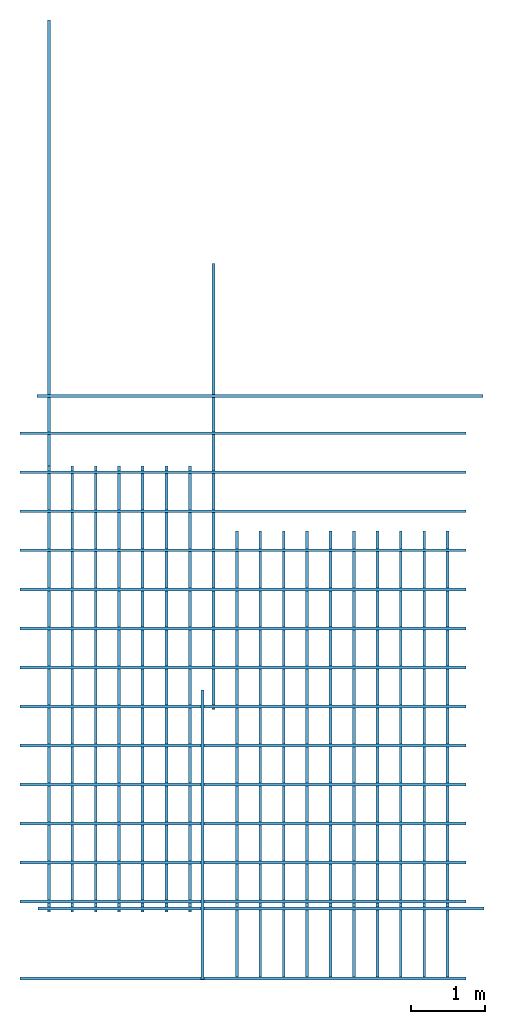
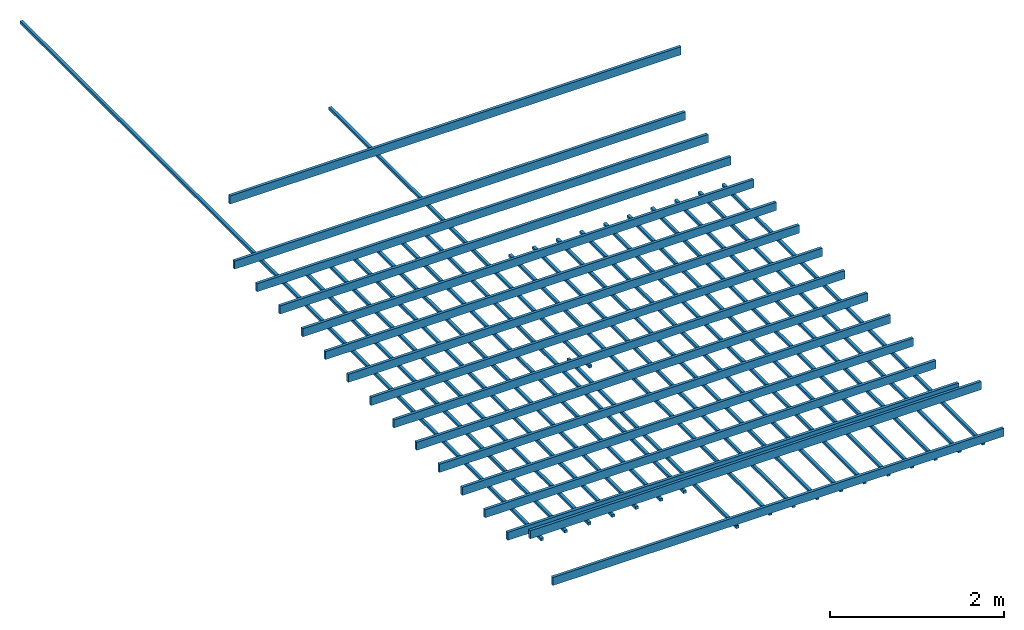
# One storey: 36 beams.
"""IFC4 building model written with IfcOpenShell, lengths in millimetres."""

from ifc_helpers import new_model, entity, si_unit, converted_unit, frame, origin_with_axes, origin_2d_with_axis, place, context, subcontext, project, spatial, line, indexed_curve, rectangle, outline, extrude, material, material_profile, profile_set, profile_usage, type_object, element, save


model = new_model("IFC4")

# Units and contexts
model_context = context("Model", 3, precision=1e-05, world=origin_with_axes())
plan_context = context("Plan", 2, precision=1e-05, world=origin_2d_with_axis())
body_context = subcontext(model_context, "Body", "Model", "MODEL_VIEW")
ifc_project = project(units=[si_unit("VOLUMEUNIT", "CUBIC_METRE"), si_unit("LENGTHUNIT", "METRE", prefix="MILLI"), converted_unit("PLANEANGLEUNIT", "degree", entity("IfcReal", 0.0174532925199433), si_unit("PLANEANGLEUNIT", "RADIAN"), dimensions=[0, 0, 0, 0, 0, 0, 0]), si_unit("AREAUNIT", "SQUARE_METRE")], contexts=[model_context, plan_context])

# Site, building, storey
site_placement = place(None, origin_with_axes())
site = spatial("IfcSite", under=ifc_project, at=site_placement)
building_placement = place(site_placement, origin_with_axes())
building = spatial("IfcBuilding", under=site, at=building_placement, Name="Building")
storey_placement = place(building_placement, frame((0.0, 0.0, 2300.00019073486), z_axis=(0.0, 0.0, 1.0), x_axis=(1.0, 0.0, 0.0)))
storey = spatial("IfcBuildingStorey", under=building, at=storey_placement, Name="Roof")

# Beams
beam_type_1 = type_object("IfcBeamType", Name="Timber 38x114", PredefinedType="BEAM")
for number, where, z_axis, x_axis, name in (
    (1, (1223.96659851074, 1214.93864059448, 39.6876335144074), (0.999999999999994, -7.54979012640429e-08, 7.54979012640429e-08), (7.54979012640431e-08, 0.999999999999997, 7.16093850883224e-15), "Beam"),
    (2, (1223.96659851074, 8551.95903778076, 38.4807586669953), (0.999999999999994, -7.54979012640429e-08, 7.54979012640429e-08), (7.54979012640431e-08, 0.999999999999997, 7.16093850883224e-15), "Beam"),
    (3, (1223.96659851074, 8026.95941925049, 39.6878719329865), (0.999999999999994, -7.54979012640429e-08, 7.54979012640429e-08), (7.54979012640431e-08, 0.999999999999997, 7.16093850883224e-15), "Beam"),
    (4, (1223.96659851074, 7501.95932388306, 44.5168018341096), (0.999999999999994, -7.54979012640429e-08, 7.54979012640429e-08), (7.54979012640431e-08, 0.999999999999997, 7.16093850883224e-15), "Beam"),
    (5, (1223.96659851074, 6976.95922851562, 42.1605110168488), (0.999999999999994, -7.54979012640429e-08, 7.54979012640429e-08), (7.54979012640431e-08, 0.999999999999997, 7.16093850883224e-15), "Beam"),
    (6, (1223.96659851074, 5926.95903778076, 38.6836528778107), (0.999999999999994, -7.54979012640429e-08, 7.54979012640429e-08), (7.54979012640431e-08, 0.999999999999997, 7.16093850883224e-15), "Beam"),
    (7, (1223.96659851074, 6451.95913314819, 40.4222011566193), (0.999999999999994, -7.54979012640429e-08, 7.54979012640429e-08), (7.54979012640431e-08, 0.999999999999997, 7.16093850883224e-15), "Beam"),
    (8, (1223.96659851074, 5401.95894241333, 31.6090583801301), (0.999999999999994, -7.54979012640429e-08, 7.54979012640429e-08), (7.54979012640431e-08, 0.999999999999997, 7.16093850883224e-15), "Beam"),
    (9, (1223.96659851074, 4876.9588470459, 33.8580608367951), (0.999999999999994, -7.54979012640429e-08, 7.54979012640429e-08), (7.54979012640431e-08, 0.999999999999997, 7.16093850883224e-15), "Beam"),
    (10, (1223.96659851074, 4351.95875167847, 37.4631881713898), (0.999999999999994, -7.54979012640429e-08, 7.54979012640429e-08), (7.54979012640431e-08, 0.999999999999997, 7.16093850883224e-15), "Beam"),
    (11, (1223.96659851074, 3826.95865631104, 45.7241535186799), (0.999999999999994, -7.54979012640429e-08, 7.54979012640429e-08), (7.54979012640431e-08, 0.999999999999997, 7.16093850883224e-15), "Beam"),
    (12, (1223.96659851074, 3301.9585609436, 40.8949851989777), (0.999999999999994, -7.54979012640429e-08, 7.54979012640429e-08), (7.54979012640431e-08, 0.999999999999997, 7.16093850883224e-15), "Beam"),
    (13, (1467.2474861145, 2156.57925605774, 39.6878719329865), (0.999999999999994, -7.54979012640429e-08, 7.54979012640429e-08), (7.54979012640431e-08, 0.999999999999997, 7.16093850883224e-15), "Beam"),
    (14, (1223.96659851074, 2776.95846557617, 44.5168018341096), (0.999999999999994, -7.54979012640429e-08, 7.54979012640429e-08), (7.54979012640431e-08, 0.999999999999997, 7.16093850883224e-15), "Beam"),
    (15, (1223.96659851074, 2251.95837020874, 45.7241535186799), (0.999999999999994, -7.54979012640429e-08, 7.54979012640429e-08), (7.54979012640431e-08, 0.999999999999997, 7.16093850883224e-15), "Beam"),
    (16, (1455.58261871338, 9051.95903778076, 570.973873138431), (0.999999999999994, -7.54979012640429e-08, 7.54979012640429e-08), (7.54979012640431e-08, 0.999999999999997, 2.50461873463336e-11), "Beam"),
):
    element("IfcBeam", number, at=place(storey_placement, frame(where, z_axis=z_axis, x_axis=x_axis)), inside=storey, type_object=beam_type_1, Name=name, context=body_context, shape_type="SweptSolid", body=[
        extrude(outline(indexed_curve([(0.0, 0.0), (37.9999987781048, 0.0), (37.9999987781048, 114.000000059605), (0.0, 114.000000059605)], segments=[line(3, 2), line(2, 1), line(1, 4), line(4, 3)], self_intersect=False)), origin_with_axes(), (0.0, 0.0, 1.0), 6000.00047683716),
    ])
ifc_material = material(Name="-test 240326")
ifc_material_profile = material_profile(ifc_material, rectangle(XDim=38.0, YDim=38.0))
ifc_profile_set = profile_set([ifc_material_profile])
ifc_profile_usage_1 = profile_usage(ifc_profile_set, cardinal=5)
beam_type_2 = type_object("IfcBeamType", Name="Timber 38x38x600", PredefinedType="BEAM", material=ifc_profile_set)
beam_1_placement = place(storey_placement, frame((1612.04659938812, 2131.15119934082, 3.10862446895044e-12), z_axis=(1.50995802528084e-07, 0.999999999999986, 7.54979012640422e-08), x_axis=(-0.999999999999989, 1.50995802528085e-07, 7.16093766179923e-15)))
element("IfcBeam", 17, at=beam_1_placement, inside=storey, type_object=beam_type_2, material=ifc_profile_usage_1, Name="Beam", context=body_context, shape_type="SweptSolid", body=[
    extrude(rectangle(XDim=38.0, YDim=38.0), origin_with_axes(), (0.0, 0.0, 1.0), 6000.00047683716),
])
ifc_profile_usage_2 = profile_usage(ifc_profile_set, cardinal=5)
beam_2_placement = place(storey_placement, frame((1927.04665660858, 2131.15119934082, 3.10862446895044e-12), z_axis=(1.50995802528084e-07, 0.999999999999986, 7.54979012640422e-08), x_axis=(-0.999999999999989, 1.50995802528085e-07, 7.16093766179923e-15)))
element("IfcBeam", 18, at=beam_2_placement, inside=storey, type_object=beam_type_2, material=ifc_profile_usage_2, Name="Beam", context=body_context, shape_type="SweptSolid", body=[
    extrude(rectangle(XDim=38.0, YDim=38.0), origin_with_axes(), (0.0, 0.0, 1.0), 6000.00047683716),
])
ifc_profile_usage_3 = profile_usage(ifc_profile_set, cardinal=5)
beam_3_placement = place(storey_placement, frame((2242.04659461975, 2131.15119934082, 3.10862446895044e-12), z_axis=(1.50995802528084e-07, 0.999999999999986, 7.54979012640422e-08), x_axis=(-0.999999999999989, 1.50995802528085e-07, 7.16093766179923e-15)))
element("IfcBeam", 19, at=beam_3_placement, inside=storey, type_object=beam_type_2, material=ifc_profile_usage_3, Name="Beam", context=body_context, shape_type="SweptSolid", body=[
    extrude(rectangle(XDim=38.0, YDim=38.0), origin_with_axes(), (0.0, 0.0, 1.0), 6000.00047683716),
])
ifc_profile_usage_4 = profile_usage(ifc_profile_set, cardinal=5)
beam_4_placement = place(storey_placement, frame((2557.04665184021, 2131.15119934082, 3.10862446895044e-12), z_axis=(1.50995802528084e-07, 0.999999999999986, 7.54979012640422e-08), x_axis=(-0.999999999999989, 1.50995802528085e-07, 7.16093766179923e-15)))
element("IfcBeam", 20, at=beam_4_placement, inside=storey, type_object=beam_type_2, material=ifc_profile_usage_4, Name="Beam", context=body_context, shape_type="SweptSolid", body=[
    extrude(rectangle(XDim=38.0, YDim=38.0), origin_with_axes(), (0.0, 0.0, 1.0), 6000.00047683716),
])
ifc_profile_usage_5 = profile_usage(ifc_profile_set, cardinal=5)
beam_5_placement = place(storey_placement, frame((2872.04647064209, 2131.15119934082, 3.10862446895044e-12), z_axis=(1.50995802528084e-07, 0.999999999999986, 7.54979012640422e-08), x_axis=(-0.999999999999989, 1.50995802528085e-07, 7.16093766179923e-15)))
element("IfcBeam", 21, at=beam_5_placement, inside=storey, type_object=beam_type_2, material=ifc_profile_usage_5, Name="Beam", context=body_context, shape_type="SweptSolid", body=[
    extrude(rectangle(XDim=38.0, YDim=38.0), origin_with_axes(), (0.0, 0.0, 1.0), 6000.00047683716),
])
ifc_profile_usage_6 = profile_usage(ifc_profile_set, cardinal=5)
beam_6_placement = place(storey_placement, frame((3197.04651832581, 2131.15119934082, 3.10862446895044e-12), z_axis=(1.50995802528084e-07, 0.999999999999986, 7.54979012640422e-08), x_axis=(-0.999999999999989, 1.50995802528085e-07, 7.16093766179923e-15)))
element("IfcBeam", 22, at=beam_6_placement, inside=storey, type_object=beam_type_2, material=ifc_profile_usage_6, Name="Beam", context=body_context, shape_type="SweptSolid", body=[
    extrude(rectangle(XDim=38.0, YDim=38.0), origin_with_axes(), (0.0, 0.0, 1.0), 6000.00047683716),
])
ifc_profile_usage_7 = profile_usage(ifc_profile_set, cardinal=5)
beam_7_placement = place(storey_placement, frame((3512.04633712769, 2131.15119934082, 3.10862446895044e-12), z_axis=(1.50995802528084e-07, 0.999999999999986, 7.54979012640422e-08), x_axis=(-0.999999999999989, 1.50995802528085e-07, 7.16093766179923e-15)))
element("IfcBeam", 23, at=beam_7_placement, inside=storey, type_object=beam_type_2, material=ifc_profile_usage_7, Name="Beam", context=body_context, shape_type="SweptSolid", body=[
    extrude(rectangle(XDim=38.0, YDim=38.0), origin_with_axes(), (0.0, 0.0, 1.0), 6000.00047683716),
])
ifc_profile_usage_8 = profile_usage(ifc_profile_set, cardinal=5)
beam_8_placement = place(storey_placement, frame((3681.04648590088, 1221.15099430084, 3.10862446895044e-12), z_axis=(1.50995802528084e-07, 0.999999999999986, 7.54979012640422e-08), x_axis=(-0.999999999999989, 1.50995802528085e-07, 7.16093766179923e-15)))
element("IfcBeam", 24, at=beam_8_placement, inside=storey, type_object=beam_type_2, material=ifc_profile_usage_8, Name="Beam", context=body_context, shape_type="SweptSolid", body=[
    extrude(rectangle(XDim=38.0, YDim=38.0), origin_with_axes(), (0.0, 0.0, 1.0), 3892.605809689),
])
ifc_profile_usage_9 = profile_usage(ifc_profile_set, cardinal=5)
beam_9_placement = place(storey_placement, frame((3827.04639434814, 4857.13863372803, 3.10862446895044e-12), z_axis=(1.50995802528084e-07, 0.999999999999986, 7.54979012640422e-08), x_axis=(-0.999999999999989, 1.50995802528085e-07, 1.00485924106347e-14)))
element("IfcBeam", 25, at=beam_9_placement, inside=storey, type_object=beam_type_2, material=ifc_profile_usage_9, Name="Beam", context=body_context, shape_type="SweptSolid", body=[
    extrude(rectangle(XDim=38.0, YDim=38.0), origin_with_axes(), (0.0, 0.0, 1.0), 6000.00047683716),
])
ifc_profile_usage_10 = profile_usage(ifc_profile_set, cardinal=5)
beam_10_placement = place(storey_placement, frame((4142.0464515686, 1258.09276103973, 3.10862446895044e-12), z_axis=(1.50995802528084e-07, 0.999999999999986, 7.54979012640422e-08), x_axis=(-0.999999999999989, 1.50995802528085e-07, 7.16093766179923e-15)))
element("IfcBeam", 26, at=beam_10_placement, inside=storey, type_object=beam_type_2, material=ifc_profile_usage_10, Name="Beam", context=body_context, shape_type="SweptSolid", body=[
    extrude(rectangle(XDim=38.0, YDim=38.0), origin_with_axes(), (0.0, 0.0, 1.0), 6000.00047683716),
])
ifc_profile_usage_11 = profile_usage(ifc_profile_set, cardinal=5)
beam_11_placement = place(storey_placement, frame((4457.04650878906, 1258.09276103973, 3.10862446895044e-12), z_axis=(1.50995802528084e-07, 0.999999999999986, 7.54979012640422e-08), x_axis=(-0.999999999999989, 1.50995802528085e-07, 7.16093766179923e-15)))
element("IfcBeam", 27, at=beam_11_placement, inside=storey, type_object=beam_type_2, material=ifc_profile_usage_11, Name="Beam", context=body_context, shape_type="SweptSolid", body=[
    extrude(rectangle(XDim=38.0, YDim=38.0), origin_with_axes(), (0.0, 0.0, 1.0), 6000.00047683716),
])
ifc_profile_usage_12 = profile_usage(ifc_profile_set, cardinal=5)
beam_12_placement = place(storey_placement, frame((4772.04656600952, 1258.09276103973, 3.10862446895044e-12), z_axis=(1.50995802528084e-07, 0.999999999999986, 7.54979012640422e-08), x_axis=(-0.999999999999989, 1.50995802528085e-07, 7.16093766179923e-15)))
element("IfcBeam", 28, at=beam_12_placement, inside=storey, type_object=beam_type_2, material=ifc_profile_usage_12, Name="Beam", context=body_context, shape_type="SweptSolid", body=[
    extrude(rectangle(XDim=38.0, YDim=38.0), origin_with_axes(), (0.0, 0.0, 1.0), 6000.00047683716),
])
ifc_profile_usage_13 = profile_usage(ifc_profile_set, cardinal=5)
beam_13_placement = place(storey_placement, frame((5087.04662322998, 1258.09276103973, 3.10862446895044e-12), z_axis=(1.50995802528084e-07, 0.999999999999986, 7.54979012640422e-08), x_axis=(-0.999999999999989, 1.50995802528085e-07, 7.16093766179923e-15)))
element("IfcBeam", 29, at=beam_13_placement, inside=storey, type_object=beam_type_2, material=ifc_profile_usage_13, Name="Beam", context=body_context, shape_type="SweptSolid", body=[
    extrude(rectangle(XDim=38.0, YDim=38.0), origin_with_axes(), (0.0, 0.0, 1.0), 6000.00047683716),
])
ifc_profile_usage_14 = profile_usage(ifc_profile_set, cardinal=5)
beam_14_placement = place(storey_placement, frame((5402.04668045044, 1258.09276103973, 3.10862446895044e-12), z_axis=(1.50995802528084e-07, 0.999999999999986, 7.54979012640422e-08), x_axis=(-0.999999999999989, 1.50995802528085e-07, 7.16093766179923e-15)))
element("IfcBeam", 30, at=beam_14_placement, inside=storey, type_object=beam_type_2, material=ifc_profile_usage_14, Name="Beam", context=body_context, shape_type="SweptSolid", body=[
    extrude(rectangle(XDim=38.0, YDim=38.0), origin_with_axes(), (0.0, 0.0, 1.0), 6000.00047683716),
])
ifc_profile_usage_15 = profile_usage(ifc_profile_set, cardinal=5)
beam_15_placement = place(storey_placement, frame((5717.0467376709, 1258.09276103973, 3.10862446895044e-12), z_axis=(1.50995802528084e-07, 0.999999999999986, 7.54979012640422e-08), x_axis=(-0.999999999999989, 1.50995802528085e-07, 7.16093766179923e-15)))
element("IfcBeam", 31, at=beam_15_placement, inside=storey, type_object=beam_type_2, material=ifc_profile_usage_15, Name="Beam", context=body_context, shape_type="SweptSolid", body=[
    extrude(rectangle(XDim=38.0, YDim=38.0), origin_with_axes(), (0.0, 0.0, 1.0), 6000.00047683716),
])
ifc_profile_usage_16 = profile_usage(ifc_profile_set, cardinal=5)
beam_16_placement = place(storey_placement, frame((6032.04679489136, 1258.09276103973, 3.10862446895044e-12), z_axis=(1.50995802528084e-07, 0.999999999999986, 7.54979012640422e-08), x_axis=(-0.999999999999989, 1.50995802528085e-07, 7.16093766179923e-15)))
element("IfcBeam", 32, at=beam_16_placement, inside=storey, type_object=beam_type_2, material=ifc_profile_usage_16, Name="Beam", context=body_context, shape_type="SweptSolid", body=[
    extrude(rectangle(XDim=38.0, YDim=38.0), origin_with_axes(), (0.0, 0.0, 1.0), 6000.00047683716),
])
ifc_profile_usage_17 = profile_usage(ifc_profile_set, cardinal=5)
beam_17_placement = place(storey_placement, frame((6347.04685211182, 1258.09276103973, 3.10862446895044e-12), z_axis=(1.50995802528084e-07, 0.999999999999986, 7.54979012640422e-08), x_axis=(-0.999999999999989, 1.50995802528085e-07, 7.16093766179923e-15)))
element("IfcBeam", 33, at=beam_17_placement, inside=storey, type_object=beam_type_2, material=ifc_profile_usage_17, Name="Beam", context=body_context, shape_type="SweptSolid", body=[
    extrude(rectangle(XDim=38.0, YDim=38.0), origin_with_axes(), (0.0, 0.0, 1.0), 6000.00047683716),
])
ifc_profile_usage_18 = profile_usage(ifc_profile_set, cardinal=5)
beam_18_placement = place(storey_placement, frame((6662.04690933228, 1258.09276103973, 3.10862446895044e-12), z_axis=(1.50995802528084e-07, 0.999999999999986, 7.54979012640422e-08), x_axis=(-0.999999999999989, 1.50995802528085e-07, 7.16093766179923e-15)))
element("IfcBeam", 34, at=beam_18_placement, inside=storey, type_object=beam_type_2, material=ifc_profile_usage_18, Name="Beam", context=body_context, shape_type="SweptSolid", body=[
    extrude(rectangle(XDim=38.0, YDim=38.0), origin_with_axes(), (0.0, 0.0, 1.0), 6000.00047683716),
])
ifc_profile_usage_19 = profile_usage(ifc_profile_set, cardinal=5)
beam_19_placement = place(storey_placement, frame((6977.04696655273, 1256.35433197021, 3.10862446895044e-12), z_axis=(1.50995802528084e-07, 0.999999999999986, 7.54979012640422e-08), x_axis=(-0.999999999999989, 1.50995802528085e-07, 7.16093766179923e-15)))
element("IfcBeam", 35, at=beam_19_placement, inside=storey, type_object=beam_type_2, material=ifc_profile_usage_19, Name="Beam", context=body_context, shape_type="SweptSolid", body=[
    extrude(rectangle(XDim=38.0, YDim=38.0), origin_with_axes(), (0.0, 0.0, 1.0), 6000.00047683716),
])
ifc_profile_usage_20 = profile_usage(ifc_profile_set, cardinal=5)
beam_20_placement = place(storey_placement, frame((1612.04659938812, 8131.15119934082, 3.10862446895044e-12), z_axis=(1.50995802528084e-07, 0.999999999999986, 7.54979012640422e-08), x_axis=(-0.999999999999989, 1.50995802528085e-07, 1.00485924106347e-14)))
element("IfcBeam", 36, at=beam_20_placement, inside=storey, type_object=beam_type_2, material=ifc_profile_usage_20, Name="Beam", context=body_context, shape_type="SweptSolid", body=[
    extrude(rectangle(XDim=38.0, YDim=38.0), origin_with_axes(), (0.0, 0.0, 1.0), 6000.00047683716),
])

save(model, "model.ifc")
